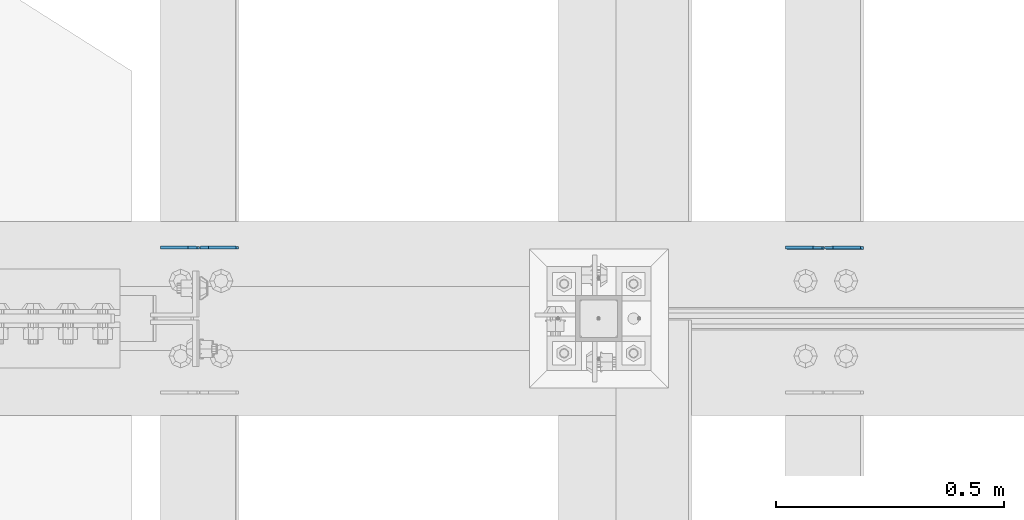
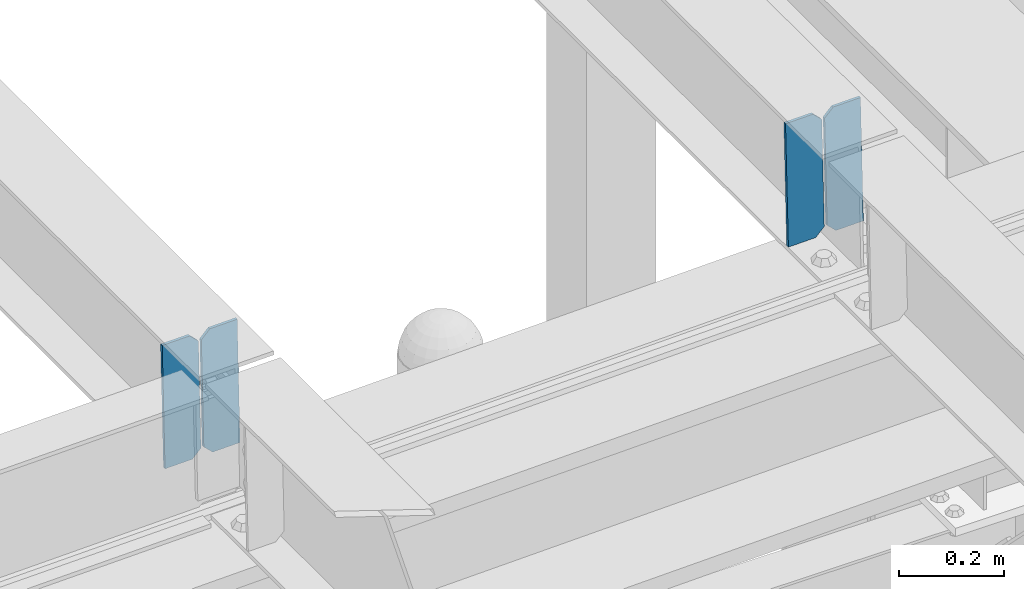
# One storey, part 3373 of 3843: 4 plates, 2 elements without a shape of their own.
"""IFC2X3 building model written with IfcOpenShell, lengths in millimetres."""

import ifcopenshell
import ifcopenshell.guid

model = None  # the IFC model being written
_history = None  # IfcOwnerHistory: only IFC2X3 demands one
_inside = {}  # id of a spatial element -> (the spatial element, [elements in it])
_under = {}  # id of a project, library or spatial element -> (it, [spatial elements below it])
_declared = {}  # id of a project -> (the project, [libraries it declares])
_typed = {}  # id of a type object -> (the type object, [elements of that type])
_made_of = {}  # id of a material, layer set ... -> (it, [elements and type objects made of it])


def new_model(schema):
    """Start an empty IFC model of exactly this schema.

    Asked for "IFC4X3", IfcOpenShell would pick the latest addendum, in which some entities
    have other attributes; the version numbers below select the first issue.
    IFC2X3 requires an IfcOwnerHistory on every rooted entity: one is made here for all.
    """
    global model, _history
    if schema == "IFC4X3":
        model = ifcopenshell.file(schema_version=(4, 3, 0, 0))
    else:
        model = ifcopenshell.file(schema=schema)
    _inside.clear()
    _under.clear()
    _declared.clear()
    _typed.clear()
    _made_of.clear()
    _history = None
    if model.schema == "IFC2X3":
        org = make("IfcOrganization", Name="unknown")
        user = make(
            "IfcPersonAndOrganization",
            ThePerson=make("IfcPerson", FamilyName="unknown"),
            TheOrganization=org,
        )
        app = make(
            "IfcApplication",
            ApplicationDeveloper=org,
            Version="unknown",
            ApplicationFullName="unknown",
            ApplicationIdentifier="unknown",
        )
        _history = make(
            "IfcOwnerHistory",
            OwningUser=user,
            OwningApplication=app,
            ChangeAction="ADDED",
            CreationDate=0,
        )
    return model


def make(cls, **values):
    """One entity of the class cls with the attributes given. An attribute that is None is left unset."""
    return model.create_entity(
        cls, **{name: value for name, value in values.items() if value is not None}
    )


def rooted(cls, **values):
    """An entity with a GlobalId (a new one), such as an element, a storey or a relation."""
    return make(cls, GlobalId=ifcopenshell.guid.new(), OwnerHistory=_history, **values)


def si_unit(unit_type, name, prefix=None):
    """IfcSIUnit, for example si_unit("LENGTHUNIT", "METRE", prefix="MILLI")."""
    return make("IfcSIUnit", UnitType=unit_type, Prefix=prefix, Name=name)


def assignment(units):
    """IfcUnitAssignment: the units of a project."""
    return None if units is None else make("IfcUnitAssignment", Units=units)


def point(xyz):
    """IfcCartesianPoint."""
    return None if xyz is None else make("IfcCartesianPoint", Coordinates=xyz)


def direction(xyz):
    """IfcDirection."""
    return None if xyz is None else make("IfcDirection", DirectionRatios=xyz)


def frame(location, z_axis=None, x_axis=None):
    """IfcAxis2Placement3D, a coordinate frame: its origin and axes. An axis left out is left unset."""
    return make(
        "IfcAxis2Placement3D",
        Location=point(location),
        Axis=direction(z_axis),
        RefDirection=direction(x_axis),
    )


def origin_with_axes():
    """The frame at (0, 0, 0) with the z axis (0, 0, 1) and the x axis (1, 0, 0) written out."""
    return frame((0.0, 0.0, 0.0), z_axis=(0.0, 0.0, 1.0), x_axis=(1.0, 0.0, 0.0))


def place(relative_to, where):
    """IfcLocalPlacement: puts the frame where relative to a parent placement (None: the world)."""
    return make(
        "IfcLocalPlacement", PlacementRelTo=relative_to, RelativePlacement=where
    )


def context(
    kind, dimensions, precision=None, world=None, true_north=None, identifier=None
):
    """IfcGeometricRepresentationContext, for example the 3D "Model" context."""
    return make(
        "IfcGeometricRepresentationContext",
        ContextIdentifier=identifier,
        ContextType=kind,
        CoordinateSpaceDimension=dimensions,
        Precision=precision,
        WorldCoordinateSystem=world,
        TrueNorth=true_north,
    )


def subcontext(parent, identifier, kind, view, scale=None):
    """IfcGeometricRepresentationSubContext, for example "Body" below "Model"."""
    return make(
        "IfcGeometricRepresentationSubContext",
        ContextIdentifier=identifier,
        ContextType=kind,
        ParentContext=parent,
        TargetScale=scale,
        TargetView=view,
    )


def project(units=None, contexts=None):
    """IfcProject with its units and contexts."""
    return rooted(
        "IfcProject",
        Name="project",
        RepresentationContexts=contexts,
        UnitsInContext=assignment(units),
    )


def spatial(cls, under=None, at=None, **own):
    """A site, building, storey or space (cls), placed at a placement, below another one or the project."""
    s = rooted(cls, ObjectPlacement=at, **own)
    if under is not None:
        _under.setdefault(under.id(), (under, []))[1].append(s)
    return s


def faces_of(points, faces, orient=None, outer=None):
    """IfcFace entities. A face is a list of loops; a loop is a list of indices into points, from 0.

    orient and outer hold one flag for each loop. By default every Orientation is true, the
    first loop of a face is its IfcFaceOuterBound and the others are IfcFaceBound.
    """
    made = []
    for i, loops in enumerate(faces):
        bounds = []
        for j, loop in enumerate(loops):
            is_outer = j == 0 if outer is None else outer[i][j]
            bounds.append(
                make(
                    "IfcFaceOuterBound" if is_outer else "IfcFaceBound",
                    Bound=make("IfcPolyLoop", Polygon=[points[k] for k in loop]),
                    Orientation=True if orient is None else orient[i][j],
                )
            )
        made.append(make("IfcFace", Bounds=bounds))
    return made


def faceted_brep(points, faces, orient=None, outer=None, voids=None):
    """IfcFacetedBrep: a solid bounded by flat faces; with voids (closed shells), ...WithVoids."""
    shared = [point(p) for p in points]
    hull = make("IfcClosedShell", CfsFaces=faces_of(shared, faces, orient, outer))
    if voids is None:
        return make("IfcFacetedBrep", Outer=hull)
    return make(
        "IfcFacetedBrepWithVoids",
        Outer=hull,
        Voids=[
            make(cls, CfsFaces=faces_of(shared, fs, o, b)) for cls, fs, o, b in voids
        ],
    )


def shape(context_of_items, identifier, shape_type, items):
    """IfcShapeRepresentation: the items that make up one representation, for example the "Body"."""
    return make(
        "IfcShapeRepresentation",
        ContextOfItems=context_of_items,
        RepresentationIdentifier=identifier,
        RepresentationType=shape_type,
        Items=items,
    )


def material(Name=None, Category=None):
    """IfcMaterial."""
    return make("IfcMaterial", Name=Name, Category=Category)


def made_of(thing, what):
    """Note that an element or type object is made of a material, layer set ...; save() writes the relation."""
    if what is not None:
        _made_of.setdefault(what.id(), (what, []))[1].append(thing)
    return thing


def type_object(cls, material=None, **own):
    """A type object (cls), such as IfcWallType, which elements share."""
    return made_of(rooted(cls, **own), material)


def element(
    cls,
    number,
    at=None,
    inside=None,
    cuts=None,
    type_object=None,
    material=None,
    context=None,
    identifier="Body",
    shape_type=None,
    held_by="IfcProductDefinitionShape",
    body=None,
    shapes=None,
    **own,
):
    """One element of the class cls, such as IfcWall. Its Tag is "e" and its number.

    at: its placement. inside: the storey or other place that contains it. cuts: it is an
    opening in that element (IfcRelVoidsElement). A single representation is given by context,
    identifier, shape_type and body (its items); several are given by shapes. held_by: the class
    of the entity that holds the representations. save() writes the other relations.
    """
    e = rooted(cls, Tag="e%d" % number, ObjectPlacement=at, **own)
    if body is not None:
        shapes = [shape(context, identifier, shape_type, body)]
    if shapes is not None:
        e.Representation = make(held_by, Representations=shapes)
    if inside is not None:
        _inside.setdefault(inside.id(), (inside, []))[1].append(e)
    if cuts is not None:
        rooted(
            "IfcRelVoidsElement", RelatingBuildingElement=cuts, RelatedOpeningElement=e
        )
    if type_object is not None:
        _typed.setdefault(type_object.id(), (type_object, []))[1].append(e)
    return made_of(e, material)


def aggregate(whole, parts):
    """IfcRelAggregates: a whole, such as a stair, and the parts it consists of."""
    return rooted("IfcRelAggregates", RelatingObject=whole, RelatedObjects=parts)


def save(model, path):
    """Write the relations noted so far, then the file.

    IfcRelAggregates (storeys below a building ...), IfcRelContainedInSpatialStructure (elements
    in a storey), IfcRelDefinesByType, IfcRelAssociatesMaterial and IfcRelDeclares: one each for
    every whole, place, type object, material and project.
    """
    for whole, parts in _under.values():
        aggregate(whole, parts)
    for where, things in _inside.values():
        rooted(
            "IfcRelContainedInSpatialStructure",
            RelatedElements=things,
            RelatingStructure=where,
        )
    for kind, things in _typed.values():
        rooted("IfcRelDefinesByType", RelatedObjects=things, RelatingType=kind)
    for what, things in _made_of.values():
        rooted("IfcRelAssociatesMaterial", RelatedObjects=things, RelatingMaterial=what)
    for by, libraries in _declared.values():
        rooted("IfcRelDeclares", RelatingContext=by, RelatedDefinitions=libraries)
    model.write(path)


model = new_model("IFC2X3")

# Units and contexts
model_context = context("Model", 3, precision=1e-05, world=origin_with_axes())
body_context = subcontext(model_context, "Body", "Model", "MODEL_VIEW")
ifc_project = project(units=[si_unit("LENGTHUNIT", "METRE", prefix="MILLI"), si_unit("AREAUNIT", "SQUARE_METRE"), si_unit("VOLUMEUNIT", "CUBIC_METRE"), si_unit("MASSUNIT", "GRAM", prefix="KILO"), si_unit("TIMEUNIT", "SECOND"), si_unit("PLANEANGLEUNIT", "RADIAN"), si_unit("SOLIDANGLEUNIT", "STERADIAN"), si_unit("THERMODYNAMICTEMPERATUREUNIT", "DEGREE_CELSIUS"), si_unit("LUMINOUSINTENSITYUNIT", "LUMEN")], contexts=[model_context])

# Site, building, storey
site_placement = place(None, origin_with_axes())
site = spatial("IfcSite", under=ifc_project, at=site_placement, CompositionType="ELEMENT")
building_placement = place(site_placement, origin_with_axes())
building = spatial("IfcBuilding", under=site, at=building_placement, Name="Undefined", CompositionType="ELEMENT")
storey_placement = place(building_placement, origin_with_axes())
storey = spatial("IfcBuildingStorey", under=building, at=storey_placement, Name="Undefined", CompositionType="ELEMENT", Elevation=0.0)

# Assembly, plates
assembly_1_placement = place(storey_placement, origin_with_axes())
assembly_1 = element("IfcElementAssembly", 1, at=assembly_1_placement, inside=storey, Name="BEAM", AssemblyPlace="NOTDEFINED", PredefinedType="RIGID_FRAME")
ifc_material = material(Name="STEEL/A572-50")
plate_type = type_object("IfcPlateType", PredefinedType="NOTDEFINED")
plate_1_placement = place(assembly_1_placement, frame((39401.4964782662, 75783.6331346296, 45502.7343879961), z_axis=(-0.0211520981891954, 0.00148016899947834, 0.999775173647519), x_axis=(-0.999776269354785, -3.22879999736168e-05, -0.0211520730074938)))
plate_1 = element("IfcPlate", 2, at=plate_1_placement, type_object=plate_type, material=ifc_material, Name="PLATE", context=body_context, shape_type="Brep", body=[
    faceted_brep([(0.0, -3.17499999999927, 0.0), (6.83940015733242e-10, -3.17499999996653, 288.924999998613), (6.54836185276508e-10, 3.17500000001746, 288.924999998591), (0.0, 3.17499999999927, 0.0), (60.3250007643655, -3.17500000017753, 288.924999998606), (60.3250007643219, 3.17499999979918, 288.924999998584), (79.3750000013097, -3.17500000025029, 269.875000761494), (79.375000001266, 3.17499999972642, 269.875000761487), (79.375000000713, -3.17500000026484, 19.0499992370605), (79.3750000006985, 3.17499999971187, 19.0499992370533), (60.325000763667, -3.17500000020664, -1.45519152283669e-11), (60.3250007636234, 3.17499999977736, -3.63797880709171e-11)], [[[0, 1, 2, 3]], [[1, 4, 5, 2]], [[4, 6, 7, 5]], [[6, 8, 9, 7]], [[8, 10, 11, 9]], [[10, 0, 3, 11]], [[5, 7, 9, 11, 3, 2]], [[10, 8, 6, 4, 1, 0]]]),
])
plate_2_placement = place(assembly_1_placement, frame((39315.7906575769, 75783.6304500932, 45500.9211263827), z_axis=(-0.0211520981891954, 0.00148016899947834, 0.999775173647519), x_axis=(-0.999776269354785, -3.22879999736168e-05, -0.0211520730074938)))
plate_2 = element("IfcPlate", 3, at=plate_2_placement, type_object=plate_type, material=ifc_material, Name="PLATE", context=body_context, shape_type="Brep", body=[
    faceted_brep([(4.36557456851006e-11, -3.17499999998836, 19.0499992370969), (6.11180439591408e-10, -3.17499999996653, 269.875000761516), (5.96628524363041e-10, 3.17500000001746, 269.875000761502), (1.45519152283669e-11, 3.17499999998836, 19.0499992370824), (19.0499992376572, -3.17500000003201, 288.924999998606), (19.0499992376281, 3.1749999999447, 288.924999998584), (79.3750000013242, -3.17500000025029, 288.924999998591), (79.3750000013097, 3.1749999997337, 288.92499999857), (79.3750000006548, -3.17500000026484, -2.18278728425503e-11), (79.3750000006403, 3.17499999969732, -2.91038304567337e-11), (19.0499992370023, -3.17500000005384, 0.0), (19.0499992369587, 3.17499999992287, -1.45519152283669e-11)], [[[0, 1, 2, 3]], [[1, 4, 5, 2]], [[4, 6, 7, 5]], [[6, 8, 9, 7]], [[8, 10, 11, 9]], [[10, 0, 3, 11]], [[5, 7, 9, 11, 3, 2]], [[10, 8, 6, 4, 1, 0]]]),
])
aggregate(assembly_1, [plate_1, plate_2])

assembly_2_placement = place(storey_placement, origin_with_axes())
assembly_2 = element("IfcElementAssembly", 4, at=assembly_2_placement, inside=storey, Name="BEAM", AssemblyPlace="NOTDEFINED", PredefinedType="RIGID_FRAME")
plate_3_placement = place(assembly_2_placement, frame((38029.8964783228, 75783.8484519464, 45467.1392528654), z_axis=(-0.0211520981056674, 0.000759183000074701, 0.999775981101217), x_axis=(-0.999776269340625, -1.63420000828851e-05, -0.0211520920071849)))
plate_3 = element("IfcPlate", 5, at=plate_3_placement, type_object=plate_type, material=ifc_material, Name="PLATE", context=body_context, shape_type="Brep", body=[
    faceted_brep([(0.0, -3.17499999999927, 0.0), (6.83940015733242e-10, -3.17499999996653, 288.924999998613), (6.54836185276508e-10, 3.17500000001746, 288.924999998591), (0.0, 3.17499999999927, 0.0), (60.3250007643655, -3.17500000017753, 288.924999998606), (60.3250007643219, 3.17499999979918, 288.924999998584), (79.3750000013097, -3.17500000025029, 269.875000761494), (79.375000001266, 3.17499999972642, 269.875000761487), (79.375000000713, -3.17500000026484, 19.0499992370605), (79.3750000006985, 3.17499999971187, 19.0499992370533), (60.325000763667, -3.17500000020664, -1.45519152283669e-11), (60.3250007636234, 3.17499999977736, -3.63797880709171e-11)], [[[0, 1, 2, 3]], [[1, 4, 5, 2]], [[4, 6, 7, 5]], [[6, 8, 9, 7]], [[8, 10, 11, 9]], [[10, 0, 3, 11]], [[5, 7, 9, 11, 3, 2]], [[10, 8, 6, 4, 1, 0]]]),
])
plate_4_placement = place(assembly_2_placement, frame((37944.1906576335, 75783.8470750391, 45465.3259897868), z_axis=(-0.0211520981056674, 0.000759183000074701, 0.999775981101217), x_axis=(-0.999776269340625, -1.63420000828851e-05, -0.0211520920071849)))
plate_4 = element("IfcPlate", 6, at=plate_4_placement, type_object=plate_type, material=ifc_material, Name="PLATE", context=body_context, shape_type="Brep", body=[
    faceted_brep([(4.36557456851006e-11, -3.17499999998836, 19.0499992370969), (6.11180439591408e-10, -3.17499999996653, 269.875000761516), (5.96628524363041e-10, 3.17500000001746, 269.875000761502), (1.45519152283669e-11, 3.17499999998836, 19.0499992370824), (19.0499992376572, -3.17500000003201, 288.924999998606), (19.0499992376281, 3.1749999999447, 288.924999998584), (79.3750000013242, -3.17500000025029, 288.924999998591), (79.3750000013097, 3.1749999997337, 288.92499999857), (79.3750000006548, -3.17500000026484, -2.18278728425503e-11), (79.3750000006403, 3.17499999969732, -2.91038304567337e-11), (19.0499992370023, -3.17500000005384, 0.0), (19.0499992369587, 3.17499999992287, -1.45519152283669e-11)], [[[0, 1, 2, 3]], [[1, 4, 5, 2]], [[4, 6, 7, 5]], [[6, 8, 9, 7]], [[8, 10, 11, 9]], [[10, 0, 3, 11]], [[5, 7, 9, 11, 3, 2]], [[10, 8, 6, 4, 1, 0]]]),
])
aggregate(assembly_2, [plate_3, plate_4])

save(model, "model.ifc")
